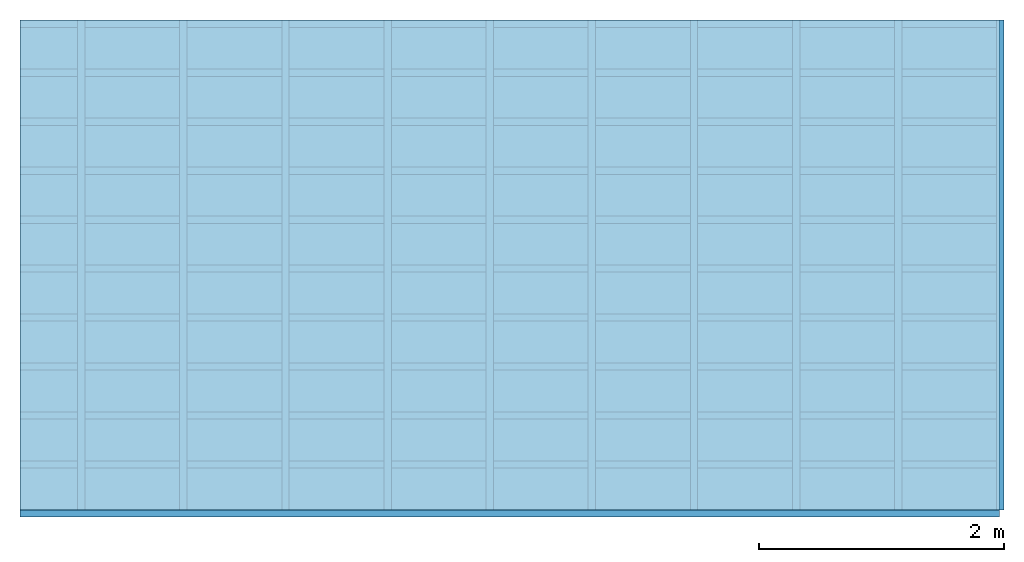
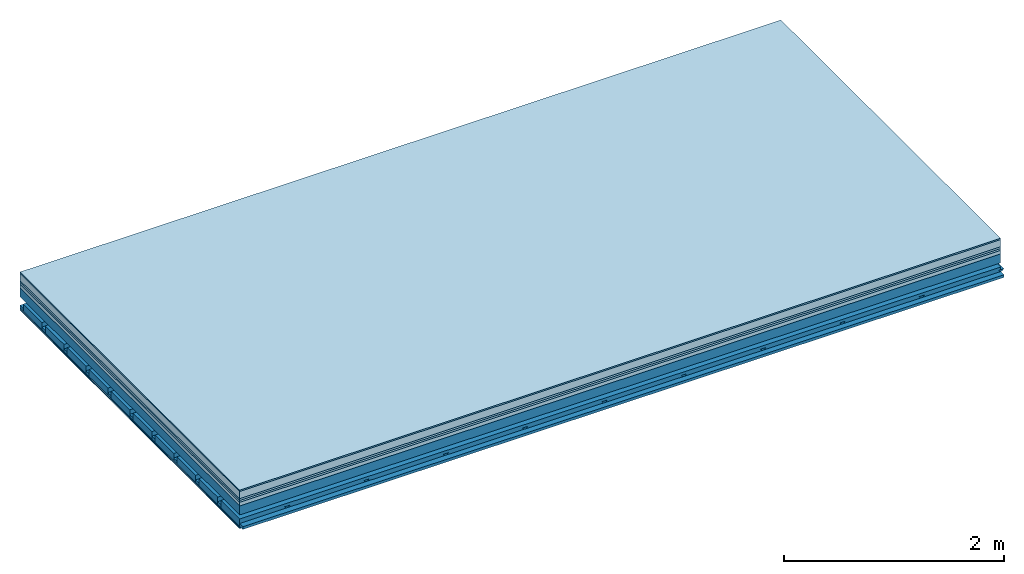
# One storey: 8 plates, 4 members, 1 element without a shape of its own.
"""IFC4 building model written with IfcOpenShell, lengths in metres."""

from ifc_helpers import new_model, si_unit, derived_unit, direction, frame, frame_2d, origin, origin_with_axes, place, context, project, spatial, polyline, rectangle, outline, extrude, material, layer, layer_set, type_object, element, aggregate, save


model = new_model("IFC4")

# Units and contexts
plan_context = context("Plan", 3, precision=1e-05, world=origin(), true_north=direction((0.0, 1.0)))
model_context = context("Model", 3, precision=1e-05, world=origin(), true_north=direction((0.0, 1.0)))
ifc_project = project(units=[si_unit("LENGTHUNIT", "METRE"), derived_unit("SOUNDPRESSUREUNIT", [(si_unit("PRESSUREUNIT", "PASCAL", prefix="MICRO"), 0)]), si_unit("ENERGYUNIT", "JOULE", prefix="MEGA"), si_unit("MASSUNIT", "GRAM", prefix="KILO"), derived_unit("THERMALTRANSMITTANCEUNIT", [(si_unit("POWERUNIT", "WATT"), 1), (si_unit("AREAUNIT", "SQUARE_METRE"), -1), (si_unit("THERMODYNAMICTEMPERATUREUNIT", "KELVIN"), -1)]), derived_unit("AREADENSITYUNIT", [(si_unit("MASSUNIT", "GRAM", prefix="KILO"), 1), (si_unit("AREAUNIT", "SQUARE_METRE"), -1)]), derived_unit("USERDEFINED", [(si_unit("ENERGYUNIT", "JOULE", prefix="MEGA"), 1), (si_unit("AREAUNIT", "SQUARE_METRE"), -1)])], contexts=[plan_context, model_context])

# Site, building, storey
site = spatial("IfcSite", under=ifc_project)
building_placement = place(None, origin())
building = spatial("IfcBuilding", under=site, at=building_placement)
storey_placement = place(building_placement, origin())
storey = spatial("IfcBuildingStorey", under=building, at=storey_placement)

# Slab, members, plates
ifc_material_1 = material(Category="11.013")
ifc_layer_1 = layer(ifc_material_1, 0.015, Name="Flooring")
ifc_material_2 = material(Name="Cement screed", Category="04.006")
ifc_layer_2 = layer(ifc_material_2, 0.08, Name="On-material")
ifc_material_3 = material(Name="Wood fiber generic product", Category="10.009")
ifc_layer_3 = layer(ifc_material_3, 0.02, Name="Impact sound insulation")
ifc_material_4 = material(Category="10.004")
ifc_layer_4 = layer(ifc_material_4, 0.02, Name="Additional insulation")
ifc_material_5 = material(Name="Garden plates", Category="02.007")
ifc_layer_5 = layer(ifc_material_5, 0.04, Name="on Supporting structure")
ifc_material_6 = material(Name="no composite action")
ifc_layer_6 = layer(ifc_material_6, 0.0, Name="Bond")
ifc_layer_7 = layer(None, 0.1, Name="Supporting structure")
ifc_layer_8 = layer(ifc_material_6, 0.0, Name="Bond")
ifc_layer_9 = layer(None, 0.095, Name="Coupling")
ifc_layer_10 = layer(None, 0.03, Name="Battens / profiles")
ifc_material_7 = material(Name="Plasterboard type A", Category="03.008")
ifc_layer_11 = layer(ifc_material_7, 0.0125, Name="Ceiling covering 1st layer")
ifc_layer_12 = layer(ifc_material_7, 0.0125, Name="Ceiling covering layer 2")
ifc_material_8 = material(Category="04.001")
ifc_layer_13 = layer(ifc_material_8, 0.003, Name="Surface / treatment")
ifc_layer_set = layer_set([ifc_layer_1, ifc_layer_2, ifc_layer_3, ifc_layer_4, ifc_layer_5, ifc_layer_6, ifc_layer_7, ifc_layer_8, ifc_layer_9, ifc_layer_10, ifc_layer_11, ifc_layer_12, ifc_layer_13])
slab_type = type_object("IfcSlabType", Name="A2167", PredefinedType="NOTDEFINED", material=ifc_layer_set)
slab_placement = place(None, frame((0.0, 0.0, 0.0), z_axis=(0.0, 0.0, -1.0), x_axis=(1.0, 0.0, 0.0)))
slab = element("IfcSlab", 1, at=slab_placement, inside=storey, type_object=slab_type, material=ifc_layer_set, Name="Slab #1")
ifc_material_9 = material(Name="Solid timber panel")
member_1_placement = place(slab_placement, origin())
member_1 = element("IfcMember", 2, at=member_1_placement, material=ifc_material_9, Name="Supporting structure", context=plan_context, shape_type="SweptSolid", body=[
    extrude(rectangle(XDim=1.0, YDim=0.1, at=frame_2d((0.5, 0.05), x_axis=(1.0, 0.0))), frame((0.0, 4.0, 0.175), z_axis=(0.0, -1.0, 0.0), x_axis=(1.0, 0.0, 0.0)), (0.0, 0.0, 1.0), 4.0),
    extrude(rectangle(XDim=1.0, YDim=0.1, at=frame_2d((0.5, 0.05), x_axis=(1.0, 0.0))), frame((1.0, 4.0, 0.175), z_axis=(0.0, -1.0, 0.0), x_axis=(1.0, 0.0, 0.0)), (0.0, 0.0, 1.0), 4.0),
    extrude(rectangle(XDim=1.0, YDim=0.1, at=frame_2d((0.5, 0.05), x_axis=(1.0, 0.0))), frame((2.0, 4.0, 0.175), z_axis=(0.0, -1.0, 0.0), x_axis=(1.0, 0.0, 0.0)), (0.0, 0.0, 1.0), 4.0),
    extrude(rectangle(XDim=1.0, YDim=0.1, at=frame_2d((0.5, 0.05), x_axis=(1.0, 0.0))), frame((3.0, 4.0, 0.175), z_axis=(0.0, -1.0, 0.0), x_axis=(1.0, 0.0, 0.0)), (0.0, 0.0, 1.0), 4.0),
    extrude(rectangle(XDim=1.0, YDim=0.1, at=frame_2d((0.5, 0.05), x_axis=(1.0, 0.0))), frame((4.0, 4.0, 0.175), z_axis=(0.0, -1.0, 0.0), x_axis=(1.0, 0.0, 0.0)), (0.0, 0.0, 1.0), 4.0),
    extrude(rectangle(XDim=1.0, YDim=0.1, at=frame_2d((0.5, 0.05), x_axis=(1.0, 0.0))), frame((5.0, 4.0, 0.175), z_axis=(0.0, -1.0, 0.0), x_axis=(1.0, 0.0, 0.0)), (0.0, 0.0, 1.0), 4.0),
    extrude(rectangle(XDim=1.0, YDim=0.1, at=frame_2d((0.5, 0.05), x_axis=(1.0, 0.0))), frame((6.0, 4.0, 0.175), z_axis=(0.0, -1.0, 0.0), x_axis=(1.0, 0.0, 0.0)), (0.0, 0.0, 1.0), 4.0),
    extrude(rectangle(XDim=1.0, YDim=0.1, at=frame_2d((0.5, 0.05), x_axis=(1.0, 0.0))), frame((7.0, 4.0, 0.175), z_axis=(0.0, -1.0, 0.0), x_axis=(1.0, 0.0, 0.0)), (0.0, 0.0, 1.0), 4.0),
])
ifc_material_10 = material()
member_2_placement = place(slab_placement, origin())
member_2 = element("IfcMember", 3, at=member_2_placement, material=ifc_material_10, Name="Coupling", context=plan_context, shape_type="SweptSolid", body=[
    extrude(outline(polyline([(0.0, 0.0), (0.06, 0.0), (0.04, 0.02), (0.02, 0.02), (0.0, 0.0)])), frame((0.47, 4.0, 0.35), z_axis=(0.0, -1.0, 0.0), x_axis=(1.0, 0.0, 0.0)), (0.0, 0.0, 1.0), 4.0),
    extrude(outline(polyline([(0.0, 0.0), (0.06, 0.0), (0.04, 0.02), (0.02, 0.02), (0.0, 0.0)])), frame((1.304, 4.0, 0.35), z_axis=(0.0, -1.0, 0.0), x_axis=(1.0, 0.0, 0.0)), (0.0, 0.0, 1.0), 4.0),
    extrude(outline(polyline([(0.0, 0.0), (0.06, 0.0), (0.04, 0.02), (0.02, 0.02), (0.0, 0.0)])), frame((2.138, 4.0, 0.35), z_axis=(0.0, -1.0, 0.0), x_axis=(1.0, 0.0, 0.0)), (0.0, 0.0, 1.0), 4.0),
    extrude(outline(polyline([(0.0, 0.0), (0.06, 0.0), (0.04, 0.02), (0.02, 0.02), (0.0, 0.0)])), frame((2.972, 4.0, 0.35), z_axis=(0.0, -1.0, 0.0), x_axis=(1.0, 0.0, 0.0)), (0.0, 0.0, 1.0), 4.0),
    extrude(outline(polyline([(0.0, 0.0), (0.06, 0.0), (0.04, 0.02), (0.02, 0.02), (0.0, 0.0)])), frame((3.806, 4.0, 0.35), z_axis=(0.0, -1.0, 0.0), x_axis=(1.0, 0.0, 0.0)), (0.0, 0.0, 1.0), 4.0),
    extrude(outline(polyline([(0.0, 0.0), (0.06, 0.0), (0.04, 0.02), (0.02, 0.02), (0.0, 0.0)])), frame((4.64, 4.0, 0.35), z_axis=(0.0, -1.0, 0.0), x_axis=(1.0, 0.0, 0.0)), (0.0, 0.0, 1.0), 4.0),
    extrude(outline(polyline([(0.0, 0.0), (0.06, 0.0), (0.04, 0.02), (0.02, 0.02), (0.0, 0.0)])), frame((5.474, 4.0, 0.35), z_axis=(0.0, -1.0, 0.0), x_axis=(1.0, 0.0, 0.0)), (0.0, 0.0, 1.0), 4.0),
    extrude(outline(polyline([(0.0, 0.0), (0.06, 0.0), (0.04, 0.02), (0.02, 0.02), (0.0, 0.0)])), frame((6.308, 4.0, 0.35), z_axis=(0.0, -1.0, 0.0), x_axis=(1.0, 0.0, 0.0)), (0.0, 0.0, 1.0), 4.0),
    extrude(outline(polyline([(0.0, 0.0), (0.06, 0.0), (0.04, 0.02), (0.02, 0.02), (0.0, 0.0)])), frame((7.142, 4.0, 0.35), z_axis=(0.0, -1.0, 0.0), x_axis=(1.0, 0.0, 0.0)), (0.0, 0.0, 1.0), 4.0),
    extrude(outline(polyline([(0.0, 0.0), (0.06, 0.0), (0.04, 0.02), (0.02, 0.02), (0.0, 0.0)])), frame((7.976, 4.0, 0.35), z_axis=(0.0, -1.0, 0.0), x_axis=(1.0, 0.0, 0.0)), (0.0, 0.0, 1.0), 4.0),
])
member_3_placement = place(slab_placement, origin())
member_3 = element("IfcMember", 4, at=member_3_placement, material=ifc_material_10, Name="Battens / profiles", context=plan_context, shape_type="SweptSolid", body=[
    extrude(rectangle(XDim=0.06, YDim=0.03, at=frame_2d((0.03, 0.015), x_axis=(1.0, 0.0))), frame((0.0, 0.0, 0.37), z_axis=(1.0, 0.0, 0.0), x_axis=(0.0, 1.0, 0.0)), (0.0, 0.0, 1.0), 8.0),
    extrude(rectangle(XDim=0.06, YDim=0.03, at=frame_2d((0.03, 0.015), x_axis=(1.0, 0.0))), frame((0.0, 0.4, 0.37), z_axis=(1.0, 0.0, 0.0), x_axis=(0.0, 1.0, 0.0)), (0.0, 0.0, 1.0), 8.0),
    extrude(rectangle(XDim=0.06, YDim=0.03, at=frame_2d((0.03, 0.015), x_axis=(1.0, 0.0))), frame((0.0, 0.8, 0.37), z_axis=(1.0, 0.0, 0.0), x_axis=(0.0, 1.0, 0.0)), (0.0, 0.0, 1.0), 8.0),
    extrude(rectangle(XDim=0.06, YDim=0.03, at=frame_2d((0.03, 0.015), x_axis=(1.0, 0.0))), frame((0.0, 1.2, 0.37), z_axis=(1.0, 0.0, 0.0), x_axis=(0.0, 1.0, 0.0)), (0.0, 0.0, 1.0), 8.0),
    extrude(rectangle(XDim=0.06, YDim=0.03, at=frame_2d((0.03, 0.015), x_axis=(1.0, 0.0))), frame((0.0, 1.6, 0.37), z_axis=(1.0, 0.0, 0.0), x_axis=(0.0, 1.0, 0.0)), (0.0, 0.0, 1.0), 8.0),
    extrude(rectangle(XDim=0.06, YDim=0.03, at=frame_2d((0.03, 0.015), x_axis=(1.0, 0.0))), frame((0.0, 2.0, 0.37), z_axis=(1.0, 0.0, 0.0), x_axis=(0.0, 1.0, 0.0)), (0.0, 0.0, 1.0), 8.0),
    extrude(rectangle(XDim=0.06, YDim=0.03, at=frame_2d((0.03, 0.015), x_axis=(1.0, 0.0))), frame((0.0, 2.4, 0.37), z_axis=(1.0, 0.0, 0.0), x_axis=(0.0, 1.0, 0.0)), (0.0, 0.0, 1.0), 8.0),
    extrude(rectangle(XDim=0.06, YDim=0.03, at=frame_2d((0.03, 0.015), x_axis=(1.0, 0.0))), frame((0.0, 2.8, 0.37), z_axis=(1.0, 0.0, 0.0), x_axis=(0.0, 1.0, 0.0)), (0.0, 0.0, 1.0), 8.0),
    extrude(rectangle(XDim=0.06, YDim=0.03, at=frame_2d((0.03, 0.015), x_axis=(1.0, 0.0))), frame((0.0, 3.2, 0.37), z_axis=(1.0, 0.0, 0.0), x_axis=(0.0, 1.0, 0.0)), (0.0, 0.0, 1.0), 8.0),
    extrude(rectangle(XDim=0.06, YDim=0.03, at=frame_2d((0.03, 0.015), x_axis=(1.0, 0.0))), frame((0.0, 3.6, 0.37), z_axis=(1.0, 0.0, 0.0), x_axis=(0.0, 1.0, 0.0)), (0.0, 0.0, 1.0), 8.0),
    extrude(rectangle(XDim=0.06, YDim=0.03, at=frame_2d((0.03, 0.015), x_axis=(1.0, 0.0))), frame((0.0, 4.0, 0.37), z_axis=(1.0, 0.0, 0.0), x_axis=(0.0, 1.0, 0.0)), (0.0, 0.0, 1.0), 8.0),
])
ifc_material_11 = material()
member_4_placement = place(slab_placement, origin())
member_4 = element("IfcMember", 5, at=member_4_placement, material=ifc_material_11, Name="Cavity", context=plan_context, shape_type="SweptSolid", body=[
    extrude(rectangle(XDim=0.34, YDim=0.08, at=frame_2d((0.17, 0.04), x_axis=(1.0, 0.0))), frame((0.0, 0.06, 0.32), z_axis=(1.0, 0.0, 0.0), x_axis=(0.0, 1.0, 0.0)), (0.0, 0.0, 1.0), 8.0),
    extrude(rectangle(XDim=0.34, YDim=0.08, at=frame_2d((0.17, 0.04), x_axis=(1.0, 0.0))), frame((0.0, 0.46, 0.32), z_axis=(1.0, 0.0, 0.0), x_axis=(0.0, 1.0, 0.0)), (0.0, 0.0, 1.0), 8.0),
    extrude(rectangle(XDim=0.34, YDim=0.08, at=frame_2d((0.17, 0.04), x_axis=(1.0, 0.0))), frame((0.0, 0.86, 0.32), z_axis=(1.0, 0.0, 0.0), x_axis=(0.0, 1.0, 0.0)), (0.0, 0.0, 1.0), 8.0),
    extrude(rectangle(XDim=0.34, YDim=0.08, at=frame_2d((0.17, 0.04), x_axis=(1.0, 0.0))), frame((0.0, 1.26, 0.32), z_axis=(1.0, 0.0, 0.0), x_axis=(0.0, 1.0, 0.0)), (0.0, 0.0, 1.0), 8.0),
    extrude(rectangle(XDim=0.34, YDim=0.08, at=frame_2d((0.17, 0.04), x_axis=(1.0, 0.0))), frame((0.0, 1.66, 0.32), z_axis=(1.0, 0.0, 0.0), x_axis=(0.0, 1.0, 0.0)), (0.0, 0.0, 1.0), 8.0),
    extrude(rectangle(XDim=0.34, YDim=0.08, at=frame_2d((0.17, 0.04), x_axis=(1.0, 0.0))), frame((0.0, 2.06, 0.32), z_axis=(1.0, 0.0, 0.0), x_axis=(0.0, 1.0, 0.0)), (0.0, 0.0, 1.0), 8.0),
    extrude(rectangle(XDim=0.34, YDim=0.08, at=frame_2d((0.17, 0.04), x_axis=(1.0, 0.0))), frame((0.0, 2.46, 0.32), z_axis=(1.0, 0.0, 0.0), x_axis=(0.0, 1.0, 0.0)), (0.0, 0.0, 1.0), 8.0),
    extrude(rectangle(XDim=0.34, YDim=0.08, at=frame_2d((0.17, 0.04), x_axis=(1.0, 0.0))), frame((0.0, 2.86, 0.32), z_axis=(1.0, 0.0, 0.0), x_axis=(0.0, 1.0, 0.0)), (0.0, 0.0, 1.0), 8.0),
    extrude(rectangle(XDim=0.34, YDim=0.08, at=frame_2d((0.17, 0.04), x_axis=(1.0, 0.0))), frame((0.0, 3.26, 0.32), z_axis=(1.0, 0.0, 0.0), x_axis=(0.0, 1.0, 0.0)), (0.0, 0.0, 1.0), 8.0),
    extrude(rectangle(XDim=0.34, YDim=0.08, at=frame_2d((0.17, 0.04), x_axis=(1.0, 0.0))), frame((0.0, 3.66, 0.32), z_axis=(1.0, 0.0, 0.0), x_axis=(0.0, 1.0, 0.0)), (0.0, 0.0, 1.0), 8.0),
])
plate_1_placement = place(slab_placement, origin())
plate_1 = element("IfcPlate", 6, at=plate_1_placement, material=ifc_material_1, Name="Flooring", context=plan_context, shape_type="SweptSolid", body=[
    extrude(rectangle(XDim=8.0, YDim=4.0, at=frame_2d((4.0, 2.0), x_axis=(1.0, 0.0))), origin_with_axes(), (0.0, 0.0, 1.0), 0.015),
])
plate_2_placement = place(slab_placement, origin())
plate_2 = element("IfcPlate", 7, at=plate_2_placement, material=ifc_material_2, Name="On-material", context=plan_context, shape_type="SweptSolid", body=[
    extrude(rectangle(XDim=8.0, YDim=4.0, at=frame_2d((4.0, 2.0), x_axis=(1.0, 0.0))), frame((0.0, 0.0, 0.015), z_axis=(0.0, 0.0, 1.0), x_axis=(1.0, 0.0, 0.0)), (0.0, 0.0, 1.0), 0.08),
])
plate_3_placement = place(slab_placement, origin())
plate_3 = element("IfcPlate", 8, at=plate_3_placement, material=ifc_material_3, Name="Impact sound insulation", context=plan_context, shape_type="SweptSolid", body=[
    extrude(rectangle(XDim=8.0, YDim=4.0, at=frame_2d((4.0, 2.0), x_axis=(1.0, 0.0))), frame((0.0, 0.0, 0.095), z_axis=(0.0, 0.0, 1.0), x_axis=(1.0, 0.0, 0.0)), (0.0, 0.0, 1.0), 0.02),
])
plate_4_placement = place(slab_placement, origin())
plate_4 = element("IfcPlate", 9, at=plate_4_placement, material=ifc_material_4, Name="Additional insulation", context=plan_context, shape_type="SweptSolid", body=[
    extrude(rectangle(XDim=8.0, YDim=4.0, at=frame_2d((4.0, 2.0), x_axis=(1.0, 0.0))), frame((0.0, 0.0, 0.115), z_axis=(0.0, 0.0, 1.0), x_axis=(1.0, 0.0, 0.0)), (0.0, 0.0, 1.0), 0.02),
])
plate_5_placement = place(slab_placement, origin())
plate_5 = element("IfcPlate", 10, at=plate_5_placement, material=ifc_material_5, Name="on Supporting structure", context=plan_context, shape_type="SweptSolid", body=[
    extrude(rectangle(XDim=8.0, YDim=4.0, at=frame_2d((4.0, 2.0), x_axis=(1.0, 0.0))), frame((0.0, 0.0, 0.135), z_axis=(0.0, 0.0, 1.0), x_axis=(1.0, 0.0, 0.0)), (0.0, 0.0, 1.0), 0.04),
])
plate_6_placement = place(slab_placement, origin())
plate_6 = element("IfcPlate", 11, at=plate_6_placement, material=ifc_material_7, Name="Ceiling covering 1st layer", context=plan_context, shape_type="SweptSolid", body=[
    extrude(rectangle(XDim=8.0, YDim=4.0, at=frame_2d((4.0, 2.0), x_axis=(1.0, 0.0))), frame((0.0, 0.0, 0.4), z_axis=(0.0, 0.0, 1.0), x_axis=(1.0, 0.0, 0.0)), (0.0, 0.0, 1.0), 0.0125),
])
plate_7_placement = place(slab_placement, origin())
plate_7 = element("IfcPlate", 12, at=plate_7_placement, material=ifc_material_7, Name="Ceiling covering layer 2", context=plan_context, shape_type="SweptSolid", body=[
    extrude(rectangle(XDim=8.0, YDim=4.0, at=frame_2d((4.0, 2.0), x_axis=(1.0, 0.0))), frame((0.0, 0.0, 0.4125), z_axis=(0.0, 0.0, 1.0), x_axis=(1.0, 0.0, 0.0)), (0.0, 0.0, 1.0), 0.0125),
])
plate_8_placement = place(slab_placement, origin())
plate_8 = element("IfcPlate", 13, at=plate_8_placement, material=ifc_material_8, Name="Surface / treatment", context=plan_context, shape_type="SweptSolid", body=[
    extrude(rectangle(XDim=8.0, YDim=4.0, at=frame_2d((4.0, 2.0), x_axis=(1.0, 0.0))), frame((0.0, 0.0, 0.425), z_axis=(0.0, 0.0, 1.0), x_axis=(1.0, 0.0, 0.0)), (0.0, 0.0, 1.0), 0.003),
])
aggregate(slab, [plate_1, plate_2, plate_3, plate_4, plate_5, member_1, member_2, member_3, member_4, plate_6, plate_7, plate_8])

save(model, "model.ifc")
